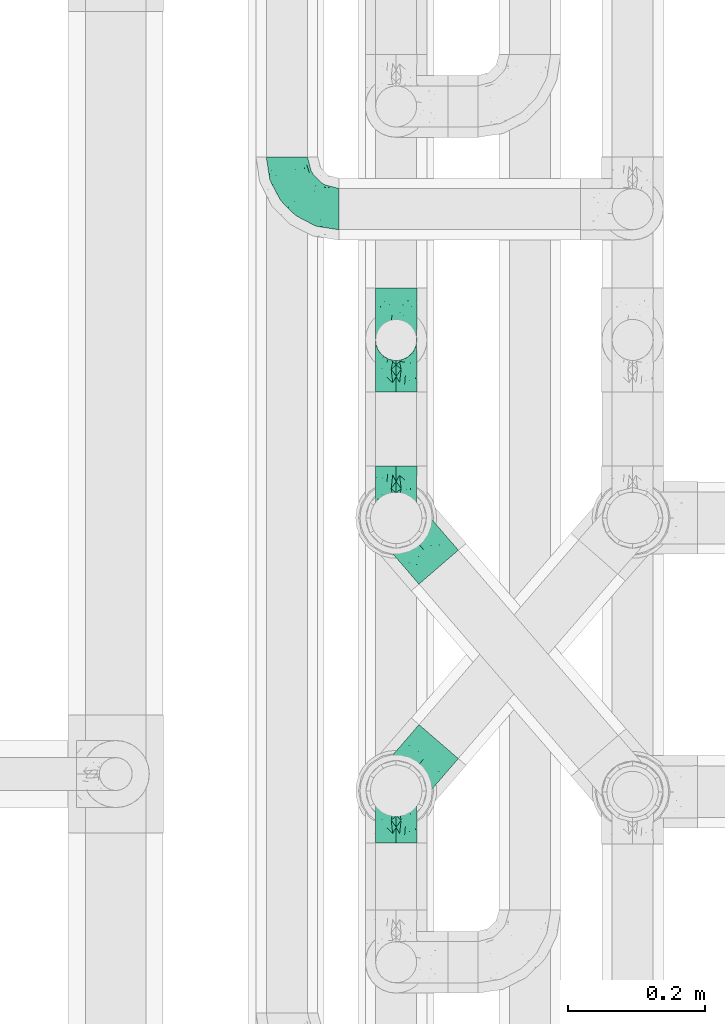
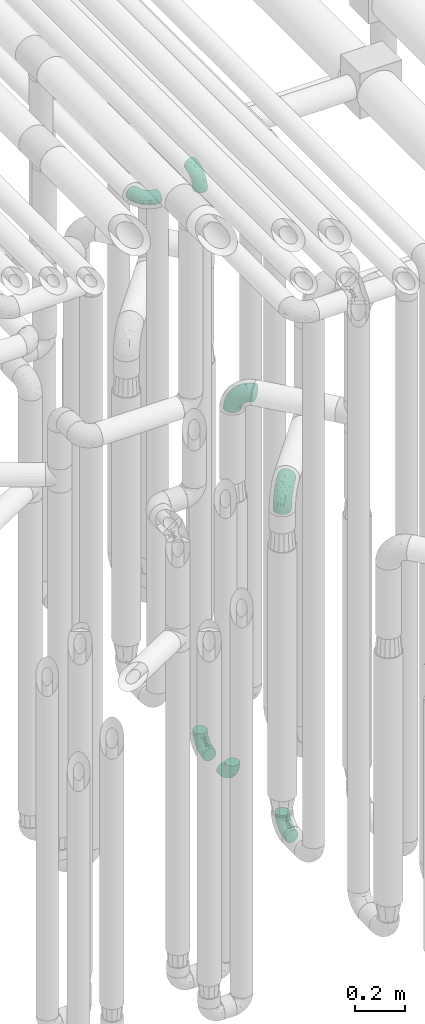
# One storey, part 615 of 827: 7 flow fittings.
"""IFC2X3 building model written with IfcOpenShell, lengths in millimetres."""

from ifc_helpers import new_model, entity, si_unit, converted_unit, derived_unit, direction, frame, origin, place, context, subcontext, project, spatial, faceted_brep, source, transform, mapped, material, type_object, type_shapes, element, save


model = new_model("IFC2X3")

# Units and contexts
model_context = context("Model", 3, precision=0.01, world=origin(), true_north=direction((6.12303176911189e-17, 1.0)))
body_context = subcontext(model_context, "Body", "Model", "MODEL_VIEW")
ifc_project = project(units=[si_unit("LENGTHUNIT", "METRE", prefix="MILLI"), si_unit("AREAUNIT", "SQUARE_METRE"), si_unit("VOLUMEUNIT", "CUBIC_METRE"), converted_unit("PLANEANGLEUNIT", "DEGREE", entity("IfcRatioMeasure", 0.0174532925199433), si_unit("PLANEANGLEUNIT", "RADIAN"), dimensions=[0, 0, 0, 0, 0, 0, 0]), si_unit("MASSUNIT", "GRAM", prefix="KILO"), derived_unit("MASSDENSITYUNIT", [(si_unit("MASSUNIT", "GRAM", prefix="KILO"), 1), (si_unit("LENGTHUNIT", "METRE"), -3)]), derived_unit("MOMENTOFINERTIAUNIT", [(si_unit("LENGTHUNIT", "METRE"), 4)]), si_unit("TIMEUNIT", "SECOND"), si_unit("FREQUENCYUNIT", "HERTZ"), si_unit("THERMODYNAMICTEMPERATUREUNIT", "DEGREE_CELSIUS"), derived_unit("THERMALTRANSMITTANCEUNIT", [(si_unit("MASSUNIT", "GRAM", prefix="KILO"), 1), (si_unit("THERMODYNAMICTEMPERATUREUNIT", "KELVIN"), -1), (si_unit("TIMEUNIT", "SECOND"), -3)]), derived_unit("VOLUMETRICFLOWRATEUNIT", [(si_unit("LENGTHUNIT", "METRE"), 3), (si_unit("TIMEUNIT", "SECOND"), -1)]), derived_unit("MASSFLOWRATEUNIT", [(si_unit("MASSUNIT", "GRAM", prefix="KILO"), 1), (si_unit("TIMEUNIT", "SECOND"), -1)]), derived_unit("ROTATIONALFREQUENCYUNIT", [(si_unit("TIMEUNIT", "SECOND"), -1)]), si_unit("ELECTRICCURRENTUNIT", "AMPERE"), si_unit("ELECTRICVOLTAGEUNIT", "VOLT"), si_unit("POWERUNIT", "WATT"), si_unit("FORCEUNIT", "NEWTON", prefix="KILO"), si_unit("ILLUMINANCEUNIT", "LUX"), si_unit("LUMINOUSFLUXUNIT", "LUMEN"), si_unit("LUMINOUSINTENSITYUNIT", "CANDELA"), derived_unit("USERDEFINED", [(si_unit("MASSUNIT", "GRAM", prefix="KILO"), -1), (si_unit("LENGTHUNIT", "METRE"), -2), (si_unit("TIMEUNIT", "SECOND"), 3), (si_unit("LUMINOUSFLUXUNIT", "LUMEN"), 1)]), derived_unit("LINEARVELOCITYUNIT", [(si_unit("LENGTHUNIT", "METRE"), 1), (si_unit("TIMEUNIT", "SECOND"), -1)]), si_unit("PRESSUREUNIT", "PASCAL"), derived_unit("USERDEFINED", [(si_unit("LENGTHUNIT", "METRE"), -2), (si_unit("MASSUNIT", "GRAM", prefix="KILO"), 1), (si_unit("TIMEUNIT", "SECOND"), -2)]), derived_unit("LINEARFORCEUNIT", [(si_unit("MASSUNIT", "GRAM", prefix="KILO"), 1), (si_unit("LENGTHUNIT", "METRE"), 1), (si_unit("TIMEUNIT", "SECOND"), -2), (si_unit("LENGTHUNIT", "METRE"), -1)]), derived_unit("PLANARFORCEUNIT", [(si_unit("MASSUNIT", "GRAM", prefix="KILO"), 1), (si_unit("LENGTHUNIT", "METRE"), 1), (si_unit("TIMEUNIT", "SECOND"), -2), (si_unit("LENGTHUNIT", "METRE"), -2)])], contexts=[model_context])

# Site, building, storey
site_placement = place(None, origin())
site = spatial("IfcSite", under=ifc_project, at=site_placement, CompositionType="ELEMENT")
building_placement = place(site_placement, origin())
building = spatial("IfcBuilding", under=site, at=building_placement, CompositionType="ELEMENT")
storey_placement = place(building_placement, frame((0.0, 0.0, 28200.0)))
storey = spatial("IfcBuildingStorey", under=building, at=storey_placement, Name="08", CompositionType="ELEMENT", Elevation=28200.0)

# Flow fittings
ifc_material = material()
pipe_fitting_type_1 = type_object("IfcPipeFittingType", Name="ADSK_1", PredefinedType="NOTDEFINED", material=ifc_material)
shared_shape_1 = source(origin(), body_context, "Body", "Brep", [
    faceted_brep([(-76.0, 15.07, -26.11), (-76.0, 7.8, -29.12), (-76.0, 0.0, -30.15), (-76.0, -7.8, -29.12), (-76.0, -15.08, -26.11), (-76.0, -21.32, -21.32), (-76.0, -26.11, -15.08), (-76.0, -29.12, -7.8), (-76.0, -30.15, 0.0), (-76.0, -29.12, 7.8), (-76.0, -26.11, 15.07), (-76.0, -21.32, 21.32), (-76.0, -15.08, 26.11), (-76.0, -7.8, 29.12), (-76.0, 0.0, 30.15), (-76.0, 7.8, 29.12), (-76.0, 15.07, 26.11), (-76.0, 21.32, 21.32), (-76.0, 26.11, 15.07), (-76.0, 29.12, 7.8), (-76.0, 30.15, 0.0), (-76.0, 29.12, -7.8), (-76.0, 26.11, -15.08), (-76.0, 21.32, -21.32), (0.0, 76.0, -30.15), (-7.8, 76.0, -29.12), (-15.07, 76.0, -26.11), (-21.32, 76.0, -21.32), (-26.11, 76.0, -15.08), (-29.12, 76.0, -7.8), (-30.15, 76.0, 0.0), (-29.12, 76.0, 7.8), (-26.11, 76.0, 15.07), (-21.32, 76.0, 21.32), (-15.07, 76.0, 26.11), (-7.8, 76.0, 29.12), (0.0, 76.0, 30.15), (7.8, 76.0, 29.12), (15.08, 76.0, 26.11), (21.32, 76.0, 21.32), (26.11, 76.0, 15.07), (29.12, 76.0, 7.8), (30.15, 76.0, 0.0), (29.12, 76.0, -7.8), (26.11, 76.0, -15.08), (21.32, 76.0, -21.32), (15.08, 76.0, -26.11), (7.8, 76.0, -29.12), (10.79, 31.43, 21.07), (4.32, 31.7, 25.72), (1.65, 15.19, 19.92), (-61.17, -27.8, 0.0), (-51.1, -25.49, 9.84), (-56.14, -10.61, 27.27), (-31.7, -4.32, 25.72), (-39.75, 1.72, 29.41), (-43.2, -24.95, 0.0), (-1.86, 1.86, 0.0), (4.49, 7.65, 5.78), (-7.82, -4.61, 5.83), (-56.21, -22.79, 17.21), (-58.98, -3.38, 29.7), (-53.96, 5.6, 30.07), (-10.86, 10.86, 25.48), (-17.2, -2.6, 20.44), (-49.15, -16.01, 22.7), (-22.18, -14.24, 7.99), (-28.4, -17.42, 0.0), (-13.61, -9.88, 0.0), (-39.0, 23.48, 27.76), (-58.76, 12.54, 28.36), (-41.61, 15.41, 29.48), (16.01, 49.15, 22.7), (-58.55, 25.93, 19.53), (-51.53, 33.5, 13.51), (-64.92, 28.76, 12.4), (-7.48, 23.14, 28.25), (-1.72, 39.75, 29.41), (-12.04, 27.88, 29.88), (-63.91, 18.81, 24.52), (-11.63, 65.16, 28.18), (-4.97, 57.02, 30.05), (9.88, 13.61, 0.0), (-62.5, 31.74, 5.02), (-45.17, 30.98, 21.2), (-21.78, 9.76, 28.58), (10.61, 56.14, 27.27), (-32.09, 54.42, 13.26), (22.79, 56.21, 17.21), (15.38, 31.17, 15.63), (25.49, 51.1, 9.84), (21.84, 36.35, 5.92), (24.95, 43.2, 0.0), (3.38, 58.98, 29.7), (-31.17, -15.38, 15.63), (-39.39, 41.78, 15.45), (-34.56, 41.13, 20.79), (-39.81, -23.25, 5.49), (27.8, 61.17, 0.0), (-31.74, 62.5, 5.02), (-53.07, 36.29, 0.0), (-42.95, 42.95, 7.29), (-36.29, 53.07, 0.0), (-19.83, 58.51, 24.79), (-25.48, 60.2, 19.41), (-14.53, 50.96, 28.57), (-13.31, 37.09, 30.07), (-26.16, 40.06, 26.4), (-32.43, -10.35, 21.9), (17.42, 28.4, 0.0), (14.24, 22.18, 7.99), (-38.67, 9.72, 30.15), (-24.66, 17.36, 30.09), (-37.08, 31.49, 24.99), (-49.27, 22.83, 25.24), (-20.8, 38.81, 28.63), (-27.58, 27.58, 29.2), (-36.07, -20.23, 10.71), (-15.19, -6.16, 14.9), (6.6, 15.4, 14.49), (-2.51, 2.51, 11.35), (-65.16, 11.63, -28.18), (-49.15, -16.01, -22.7), (-57.02, 4.97, -30.05), (-25.93, 58.55, -19.53), (-33.5, 51.53, -13.51), (-28.76, 64.92, -12.4), (-60.2, 25.48, -19.41), (-58.51, 19.83, -24.79), (4.61, 7.82, -5.83), (-7.65, -4.49, -5.78), (-2.51, 2.51, -11.35), (-62.5, 31.74, -5.02), (-50.96, 14.53, -28.57), (-37.09, 13.31, -30.07), (-42.95, 42.95, -7.29), (25.49, 51.1, -9.84), (22.79, 56.21, -17.21), (-40.06, 26.16, -26.4), (3.38, 58.98, -29.7), (-5.6, 53.96, -30.07), (-27.88, 12.04, -29.88), (-9.76, 21.78, -28.58), (-23.14, 7.48, -28.25), (-51.1, -25.49, -9.84), (15.38, 31.17, -15.63), (16.01, 49.15, -22.7), (-23.48, 39.0, -27.76), (-12.54, 58.76, -28.36), (-15.41, 41.61, -29.48), (-56.21, -22.79, -17.21), (-9.72, 38.67, -30.15), (-17.36, 24.66, -30.09), (-22.18, -14.24, -7.99), (-41.13, 34.56, -20.79), (-31.74, 62.5, -5.02), (-58.98, -3.38, -29.7), (-31.17, -15.38, -15.63), (-56.14, -10.61, -27.27), (14.24, 22.18, -7.99), (23.25, 39.81, -5.49), (-31.49, 37.08, -24.99), (-15.19, -6.16, -14.9), (1.65, 15.19, -19.92), (-18.81, 63.91, -24.52), (-32.59, -11.62, -20.84), (-31.7, -4.32, -25.72), (-17.2, -2.6, -20.44), (-39.75, 1.72, -29.41), (-54.42, 32.09, -13.26), (-30.98, 45.17, -21.2), (10.61, 56.14, -27.27), (10.23, 31.31, -21.52), (4.32, 31.7, -25.72), (-41.78, 39.39, -15.45), (-1.72, 39.75, -29.41), (-36.35, -21.84, -5.92), (-22.83, 49.27, -25.24), (-38.81, 20.8, -28.63), (-27.58, 27.58, -29.2), (-10.86, 10.86, -25.48), (20.23, 36.07, -10.71), (6.6, 15.4, -14.49)], [[[0, 1, 2, 3, 4, 5, 6, 7, 8, 9, 10, 11, 12, 13, 14, 15, 16, 17, 18, 19, 20, 21, 22, 23]], [[24, 25, 26, 27, 28, 29, 30, 31, 32, 33, 34, 35, 36, 37, 38, 39, 40, 41, 42, 43, 44, 45, 46, 47]], [[48, 49, 50]], [[51, 52, 9]], [[53, 54, 55]], [[9, 52, 10]], [[56, 52, 51]], [[57, 58, 59]], [[11, 10, 60]], [[14, 61, 62]], [[63, 54, 64]], [[65, 12, 11]], [[65, 53, 12]], [[66, 67, 68]], [[69, 70, 71]], [[72, 39, 38]], [[73, 74, 75]], [[15, 70, 16]], [[76, 77, 78]], [[16, 79, 17]], [[13, 61, 14]], [[35, 80, 81]], [[14, 62, 15]], [[17, 73, 18]], [[57, 82, 58]], [[20, 19, 83]], [[75, 19, 18]], [[70, 15, 62]], [[73, 84, 74]], [[78, 85, 76]], [[38, 86, 72]], [[32, 31, 87]], [[88, 89, 90]], [[91, 92, 90]], [[72, 86, 49]], [[36, 93, 37]], [[75, 83, 19]], [[36, 35, 81]], [[60, 94, 65]], [[40, 90, 41]], [[95, 96, 87]], [[88, 90, 40]], [[66, 97, 67]], [[90, 98, 41]], [[40, 39, 88]], [[99, 31, 30]], [[20, 83, 100]], [[101, 102, 100]], [[52, 60, 10]], [[102, 99, 30]], [[96, 103, 104]], [[83, 101, 100]], [[12, 53, 13]], [[104, 103, 33]], [[105, 106, 81]], [[107, 105, 103]], [[64, 54, 108]], [[80, 103, 105]], [[80, 35, 34]], [[34, 33, 103]], [[86, 38, 37]], [[109, 110, 82]], [[71, 111, 112]], [[69, 107, 113]], [[79, 73, 17]], [[114, 113, 84]], [[33, 32, 104]], [[115, 107, 116]], [[105, 115, 106]], [[93, 81, 77]], [[54, 53, 65]], [[61, 53, 55]], [[108, 94, 64]], [[54, 63, 85]], [[93, 86, 37]], [[77, 76, 49]], [[77, 49, 86]], [[49, 63, 50]], [[60, 52, 117]], [[65, 11, 60]], [[39, 72, 88]], [[89, 88, 72]], [[71, 70, 62]], [[79, 70, 114]], [[103, 96, 107]], [[69, 113, 114]], [[112, 106, 116]], [[77, 81, 106]], [[112, 116, 71]], [[112, 55, 85]], [[64, 50, 63]], [[57, 59, 68]], [[32, 87, 104]], [[96, 104, 87]], [[94, 118, 64]], [[50, 119, 89]], [[50, 64, 118]], [[50, 89, 48]], [[81, 93, 36]], [[86, 93, 77]], [[53, 61, 13]], [[62, 61, 55]], [[71, 62, 111]], [[69, 71, 116]], [[95, 101, 74]], [[99, 101, 87]], [[118, 66, 59]], [[117, 97, 66]], [[117, 66, 94]], [[91, 89, 110]], [[91, 110, 109]], [[110, 89, 119]], [[9, 8, 51]], [[98, 90, 92]], [[98, 42, 41]], [[101, 83, 74]], [[101, 99, 102]], [[87, 31, 99]], [[62, 55, 111]], [[55, 112, 111]], [[107, 69, 116]], [[70, 69, 114]], [[107, 96, 113]], [[84, 113, 96]], [[84, 96, 95]], [[114, 84, 73]], [[70, 79, 16]], [[73, 79, 114]], [[54, 85, 55]], [[76, 85, 63]], [[49, 76, 63]], [[77, 106, 78]], [[106, 112, 78]], [[85, 78, 112]], [[73, 75, 18]], [[83, 75, 74]], [[103, 80, 34]], [[81, 80, 105]], [[101, 95, 87]], [[84, 95, 74]], [[106, 115, 116]], [[105, 107, 115]], [[120, 59, 58]], [[82, 110, 58]], [[119, 58, 110]], [[118, 59, 120]], [[66, 68, 59]], [[54, 65, 108]], [[94, 108, 65]], [[66, 118, 94]], [[50, 118, 120]], [[50, 120, 119]], [[119, 120, 58]], [[89, 72, 48]], [[49, 48, 72]], [[60, 117, 94]], [[117, 52, 97]], [[52, 56, 97]], [[67, 97, 56]], [[92, 91, 109]], [[89, 91, 90]], [[121, 1, 0]], [[122, 5, 4]], [[2, 1, 123]], [[124, 125, 126]], [[127, 128, 23]], [[129, 130, 131]], [[100, 132, 20]], [[133, 134, 123]], [[135, 100, 102]], [[136, 137, 44]], [[133, 128, 138]], [[24, 139, 140]], [[141, 142, 143]], [[121, 128, 133]], [[6, 144, 7]], [[137, 145, 146]], [[144, 51, 7]], [[147, 148, 149]], [[144, 6, 150]], [[149, 151, 152]], [[153, 68, 67]], [[154, 128, 127]], [[30, 155, 102]], [[43, 42, 98]], [[156, 3, 2]], [[157, 144, 150]], [[158, 4, 3]], [[24, 140, 25]], [[155, 135, 102]], [[159, 160, 109]], [[30, 29, 155]], [[147, 138, 161]], [[27, 124, 28]], [[57, 129, 82]], [[162, 163, 131]], [[27, 26, 164]], [[148, 26, 25]], [[165, 166, 167]], [[24, 47, 139]], [[143, 168, 141]], [[22, 21, 169]], [[125, 124, 170]], [[148, 25, 140]], [[46, 146, 171]], [[158, 122, 4]], [[0, 23, 128]], [[1, 121, 123]], [[109, 82, 159]], [[45, 44, 137]], [[146, 46, 45]], [[136, 43, 98]], [[132, 21, 20]], [[136, 98, 92]], [[172, 173, 146]], [[46, 171, 47]], [[43, 136, 44]], [[174, 154, 169]], [[171, 173, 175]], [[6, 5, 150]], [[126, 29, 28]], [[176, 56, 144]], [[122, 158, 166]], [[164, 124, 27]], [[177, 161, 170]], [[23, 22, 127]], [[178, 138, 179]], [[133, 178, 134]], [[156, 123, 168]], [[156, 158, 3]], [[168, 143, 166]], [[168, 166, 158]], [[166, 180, 167]], [[173, 171, 146]], [[139, 171, 175]], [[172, 145, 163]], [[173, 180, 142]], [[5, 122, 150]], [[157, 150, 122]], [[137, 136, 181]], [[146, 45, 137]], [[149, 148, 140]], [[164, 148, 177]], [[128, 154, 138]], [[147, 161, 177]], [[152, 134, 179]], [[168, 123, 134]], [[152, 179, 149]], [[152, 175, 142]], [[57, 130, 129]], [[157, 165, 167]], [[22, 169, 127]], [[154, 127, 169]], [[163, 167, 180]], [[162, 157, 167]], [[173, 163, 180]], [[182, 163, 145]], [[123, 156, 2]], [[158, 156, 168]], [[171, 139, 47]], [[140, 139, 175]], [[149, 140, 151]], [[147, 149, 179]], [[174, 135, 125]], [[132, 135, 169]], [[176, 157, 153]], [[176, 153, 67]], [[153, 157, 162]], [[182, 159, 129]], [[181, 160, 159]], [[181, 159, 145]], [[51, 144, 56]], [[51, 8, 7]], [[135, 132, 100]], [[169, 21, 132]], [[126, 155, 29]], [[135, 155, 125]], [[140, 175, 151]], [[175, 152, 151]], [[138, 147, 179]], [[148, 147, 177]], [[138, 154, 161]], [[170, 161, 154]], [[170, 154, 174]], [[177, 170, 124]], [[148, 164, 26]], [[124, 164, 177]], [[173, 142, 175]], [[143, 142, 180]], [[166, 143, 180]], [[168, 134, 141]], [[134, 152, 141]], [[142, 141, 152]], [[124, 126, 28]], [[155, 126, 125]], [[128, 121, 0]], [[123, 121, 133]], [[135, 174, 169]], [[170, 174, 125]], [[134, 178, 179]], [[133, 138, 178]], [[130, 153, 162]], [[68, 153, 130]], [[57, 68, 130]], [[182, 129, 131]], [[159, 82, 129]], [[157, 122, 165]], [[166, 165, 122]], [[163, 162, 167]], [[162, 131, 130]], [[145, 172, 146]], [[163, 173, 172]], [[159, 182, 145]], [[131, 163, 182]], [[56, 176, 67]], [[157, 176, 144]], [[137, 181, 145]], [[181, 136, 160]], [[136, 92, 160]], [[109, 160, 92]]]),
])
type_shapes(pipe_fitting_type_1, [shared_shape_1])
for number, where, z_axis, x_axis, name in (
    (1, (36470.03, 12181.17, 3000.0), (0.0, 0.0, 1.0), (0.0, -1.0, 0.0), "ADSK_1"),
    (2, (36629.64, 11730.2, 400.0), (-1.0, 0.0, 0.0), (0.0, -1.0, 0.0), "ADSK_1"),
    (3, (36629.64, 11331.59, 400.0), (1.0, 0.0, 0.0), (0.0, 1.0, 0.0), "ADSK_1"),
    (4, (36629.64, 11990.2, 3200.0), (1.0, 0.0, 0.0), (0.0, -1.0, 0.0), "ADSK_1"),
    (5, (36629.64, 11990.2, 400.0), (1.0, 0.0, 0.0), (0.0, 1.0, 0.0), "ADSK_1"),
):
    element("IfcFlowFitting", number, at=place(storey_placement, frame(where, z_axis=z_axis, x_axis=x_axis)), inside=storey, type_object=pipe_fitting_type_1, material=ifc_material, Name=name, ObjectType="ADSK_1", context=body_context, shape_type="MappedRepresentation", body=[
        mapped(shared_shape_1, transform((0.0, 0.0, 0.0), scale=1.0)),
    ])
pipe_fitting_type_2 = type_object("IfcPipeFittingType", Name="ADSK_1", PredefinedType="NOTDEFINED", material=ifc_material)
shared_shape_2 = source(origin(), body_context, "Body", "Brep", [
    faceted_brep([(-95.0, 19.02, -32.95), (-95.0, 9.85, -36.75), (-95.0, 0.0, -38.05), (-95.0, -9.85, -36.75), (-95.0, -19.03, -32.95), (-95.0, -26.91, -26.91), (-95.0, -32.95, -19.03), (-95.0, -36.75, -9.85), (-95.0, -38.05, 0.0), (-95.0, -36.75, 9.85), (-95.0, -32.95, 19.02), (-95.0, -26.91, 26.91), (-95.0, -19.03, 32.95), (-95.0, -9.85, 36.75), (-95.0, 0.0, 38.05), (-95.0, 9.85, 36.75), (-95.0, 19.02, 32.95), (-95.0, 26.91, 26.91), (-95.0, 32.95, 19.02), (-95.0, 36.75, 9.85), (-95.0, 38.05, 0.0), (-95.0, 36.75, -9.85), (-95.0, 32.95, -19.03), (-95.0, 26.91, -26.91), (0.0, 95.0, -38.05), (-9.85, 95.0, -36.75), (-19.02, 95.0, -32.95), (-26.91, 95.0, -26.91), (-32.95, 95.0, -19.03), (-36.75, 95.0, -9.85), (-38.05, 95.0, 0.0), (-36.75, 95.0, 9.85), (-32.95, 95.0, 19.02), (-26.91, 95.0, 26.91), (-19.02, 95.0, 32.95), (-9.85, 95.0, 36.75), (0.0, 95.0, 38.05), (9.85, 95.0, 36.75), (19.03, 95.0, 32.95), (26.91, 95.0, 26.91), (32.95, 95.0, 19.02), (36.75, 95.0, 9.85), (38.05, 95.0, 0.0), (36.75, 95.0, -9.85), (32.95, 95.0, -19.03), (26.91, 95.0, -26.91), (19.03, 95.0, -32.95), (9.85, 95.0, -36.75), (-7.99, -4.96, 6.3), (-0.92, 0.92, 0.0), (4.62, 8.1, 8.01), (-76.19, -35.57, 0.0), (-64.32, -32.32, 12.43), (20.51, 62.45, 28.68), (-60.56, -33.52, 0.0), (-70.4, -13.47, 34.42), (-39.61, -5.88, 32.32), (-49.6, 2.07, 37.1), (-70.34, -28.81, 21.71), (14.64, 40.81, 26.5), (5.88, 39.61, 32.32), (3.59, 20.77, 25.31), (-40.45, 68.06, 16.75), (-62.45, -20.51, 28.68), (-44.52, -26.87, 0.0), (-28.47, -20.22, 0.0), (-26.43, -17.83, 8.75), (-76.1, 39.63, 10.76), (-72.74, 37.58, 18.19), (-60.35, 46.18, 14.61), (-13.4, 13.4, 32.12), (-20.77, -3.59, 25.31), (-14.66, 81.47, 35.56), (-6.22, 71.26, 37.92), (-57.5, 42.48, 22.79), (-15.0, 34.74, 37.7), (-27.1, 12.08, 36.05), (-9.2, 28.81, 35.63), (-79.98, 23.7, 30.95), (-73.68, -4.3, 37.48), (-30.74, 21.67, 37.97), (-62.36, 47.59, 6.79), (-72.71, 32.83, 24.69), (-67.42, 7.02, 37.95), (-32.13, 75.27, 24.51), (-43.46, 51.47, 26.26), (-24.98, 73.15, 31.29), (20.59, 41.28, 19.85), (7.79, 16.09, 15.86), (-73.21, 42.39, 0.0), (-54.73, 54.73, 0.0), (-73.44, 15.79, 35.79), (-5.94, 4.32, 20.43), (28.81, 70.34, 21.71), (32.32, 64.32, 12.43), (-53.59, 26.2, 35.09), (-52.02, 19.31, 37.21), (21.38, 33.53, 10.34), (26.87, 44.52, 0.0), (-48.28, 12.14, 38.05), (4.3, 73.68, 37.48), (-44.08, -25.52, 12.79), (-41.28, -20.59, 19.85), (35.57, 76.19, 0.0), (-47.26, 54.3, 20.18), (-47.4, 61.99, 8.58), (-42.39, 73.21, 0.0), (-39.67, 78.86, 7.21), (-45.69, 36.84, 33.11), (-32.83, 50.13, 33.35), (13.47, 70.4, 34.42), (-18.25, 63.73, 36.07), (-40.63, -13.75, 27.22), (-16.63, 46.37, 37.95), (-53.47, 38.79, 28.59), (-26.07, 48.54, 36.15), (-34.51, 34.51, 36.86), (-2.07, 49.6, 37.1), (-22.79, -10.49, 19.23), (-61.73, 28.67, 31.87), (9.65, 14.7, 0.0), (20.22, 28.47, 0.0), (33.52, 60.56, 0.0), (-11.42, -5.44, 13.25), (-14.7, -9.65, 0.0), (-81.47, 14.66, -35.56), (-62.45, -20.51, -28.68), (-71.26, 6.22, -37.92), (-75.27, 32.13, -24.51), (-73.15, 24.98, -31.29), (13.47, 70.4, -34.42), (5.88, 39.61, -32.32), (-2.07, 49.6, -37.1), (-78.86, 39.67, -7.21), (-70.4, -13.47, -34.42), (-39.61, -5.88, -32.32), (-61.99, 47.4, -8.58), (32.32, 64.32, -12.43), (28.81, 70.34, -21.71), (-63.73, 18.25, -36.07), (-50.13, 32.83, -33.35), (4.3, 73.68, -37.48), (-7.02, 67.42, -37.95), (-39.63, 76.1, -10.76), (-46.18, 60.35, -14.61), (-47.59, 62.36, -6.79), (-64.32, -32.32, -12.43), (-26.2, 53.59, -35.09), (-15.79, 73.44, -35.79), (-19.31, 52.02, -37.21), (-37.58, 72.74, -18.19), (-70.34, -28.81, -21.71), (-42.48, 57.5, -22.79), (-38.79, 53.47, -28.59), (-51.47, 43.46, -26.26), (-32.83, 72.71, -24.69), (-46.37, 16.63, -37.95), (-73.68, -4.3, -37.48), (-41.28, -20.59, -19.85), (-44.08, -25.52, -12.79), (13.75, 40.63, -27.22), (20.51, 62.45, -28.68), (-68.06, 40.45, -16.75), (-54.3, 47.26, -20.18), (-12.14, 48.28, -38.05), (-21.67, 30.74, -37.97), (-36.84, 45.69, -33.11), (-11.42, -5.44, -13.25), (7.79, 16.09, -15.86), (4.62, 8.1, -8.01), (-23.7, 79.98, -30.95), (-26.43, -17.83, -8.75), (-7.99, -4.96, -6.3), (-40.81, -14.64, -26.5), (-20.77, -3.59, -25.31), (-34.74, 15.0, -37.7), (-12.08, 27.1, -36.05), (-28.81, 9.2, -35.63), (-22.79, -10.49, -19.23), (21.38, 33.53, -10.34), (20.59, 41.28, -19.85), (-48.54, 26.07, -36.15), (-49.6, 2.07, -37.1), (-13.4, 13.4, -32.12), (3.59, 20.77, -25.31), (-28.67, 61.73, -31.87), (-34.51, 34.51, -36.86), (-5.94, 4.32, -20.43)], [[[0, 1, 2, 3, 4, 5, 6, 7, 8, 9, 10, 11, 12, 13, 14, 15, 16, 17, 18, 19, 20, 21, 22, 23]], [[24, 25, 26, 27, 28, 29, 30, 31, 32, 33, 34, 35, 36, 37, 38, 39, 40, 41, 42, 43, 44, 45, 46, 47]], [[48, 49, 50]], [[51, 52, 9]], [[53, 39, 38]], [[9, 52, 10]], [[54, 52, 51]], [[55, 56, 57]], [[11, 10, 58]], [[59, 60, 61]], [[32, 31, 62]], [[63, 12, 11]], [[63, 55, 12]], [[64, 65, 66]], [[67, 68, 69]], [[70, 56, 71]], [[35, 72, 73]], [[69, 68, 74]], [[75, 76, 77]], [[16, 78, 17]], [[13, 79, 14]], [[76, 75, 80]], [[67, 69, 81]], [[18, 17, 82]], [[14, 79, 83]], [[20, 19, 67]], [[84, 85, 86]], [[87, 61, 88]], [[89, 81, 90]], [[18, 82, 68]], [[15, 91, 16]], [[14, 83, 15]], [[71, 92, 61]], [[17, 78, 82]], [[93, 87, 94]], [[95, 91, 96]], [[97, 98, 94]], [[86, 72, 34]], [[96, 99, 80]], [[37, 36, 100]], [[40, 39, 93]], [[40, 94, 41]], [[64, 66, 101]], [[93, 94, 40]], [[58, 102, 63]], [[94, 103, 41]], [[94, 87, 97]], [[104, 69, 74]], [[34, 33, 86]], [[105, 69, 104]], [[52, 58, 10]], [[106, 107, 30]], [[108, 109, 85]], [[105, 106, 90]], [[53, 110, 60]], [[86, 111, 72]], [[86, 109, 111]], [[33, 84, 86]], [[12, 55, 13]], [[112, 56, 63]], [[110, 38, 37]], [[34, 72, 35]], [[36, 35, 73]], [[111, 113, 73]], [[105, 107, 106]], [[110, 53, 38]], [[74, 114, 85]], [[91, 15, 83]], [[105, 90, 81]], [[107, 62, 31]], [[33, 32, 84]], [[115, 109, 116]], [[111, 115, 113]], [[100, 73, 117]], [[56, 55, 63]], [[79, 55, 57]], [[102, 118, 112]], [[56, 70, 76]], [[100, 110, 37]], [[117, 77, 60]], [[117, 60, 110]], [[60, 70, 61]], [[58, 52, 101]], [[63, 11, 58]], [[39, 53, 93]], [[87, 93, 53]], [[96, 91, 83]], [[78, 91, 119]], [[32, 62, 84]], [[84, 62, 104]], [[86, 85, 109]], [[85, 114, 108]], [[80, 113, 116]], [[117, 73, 113]], [[80, 116, 96]], [[80, 57, 76]], [[71, 112, 118]], [[61, 87, 59]], [[62, 107, 105]], [[97, 120, 121]], [[70, 71, 61]], [[71, 118, 92]], [[73, 100, 36]], [[110, 100, 117]], [[55, 79, 13]], [[83, 79, 57]], [[96, 83, 99]], [[116, 108, 95]], [[50, 97, 88]], [[97, 87, 88]], [[50, 49, 120]], [[122, 94, 98]], [[89, 20, 67]], [[105, 81, 69]], [[89, 67, 81]], [[68, 19, 18]], [[68, 67, 19]], [[74, 68, 82]], [[114, 82, 119]], [[74, 85, 104]], [[82, 114, 74]], [[114, 119, 108]], [[95, 108, 119]], [[116, 109, 108]], [[123, 48, 50]], [[97, 50, 120]], [[123, 50, 88]], [[91, 95, 119]], [[116, 95, 96]], [[84, 104, 85]], [[104, 62, 105]], [[83, 57, 99]], [[57, 80, 99]], [[66, 48, 123]], [[66, 124, 48]], [[118, 66, 123]], [[124, 66, 65]], [[66, 118, 101]], [[54, 64, 52]], [[124, 49, 48]], [[30, 107, 31]], [[91, 78, 16]], [[82, 78, 119]], [[56, 76, 57]], [[77, 76, 70]], [[60, 77, 70]], [[77, 117, 75]], [[117, 113, 75]], [[113, 80, 75]], [[9, 8, 51]], [[103, 94, 122]], [[103, 42, 41]], [[73, 72, 111]], [[113, 115, 116]], [[111, 109, 115]], [[102, 112, 63]], [[71, 56, 112]], [[118, 102, 101]], [[92, 123, 88]], [[123, 92, 118]], [[61, 92, 88]], [[87, 53, 59]], [[60, 59, 53]], [[97, 121, 98]], [[58, 101, 102]], [[64, 101, 52]], [[125, 1, 0]], [[126, 5, 4]], [[2, 1, 127]], [[1, 125, 127]], [[128, 129, 23]], [[130, 131, 132]], [[89, 133, 20]], [[126, 134, 135]], [[136, 89, 90]], [[137, 138, 44]], [[139, 129, 140]], [[24, 141, 142]], [[143, 144, 145]], [[125, 129, 139]], [[6, 146, 7]], [[147, 148, 149]], [[146, 51, 7]], [[143, 150, 144]], [[146, 6, 151]], [[152, 153, 154]], [[126, 4, 134]], [[0, 23, 129]], [[28, 155, 150]], [[43, 42, 103]], [[54, 146, 64]], [[139, 156, 127]], [[157, 3, 2]], [[151, 158, 159]], [[160, 131, 161]], [[22, 21, 162]], [[136, 144, 163]], [[149, 164, 165]], [[24, 142, 25]], [[166, 140, 154]], [[154, 129, 128]], [[143, 30, 29]], [[167, 168, 169]], [[155, 28, 27]], [[26, 170, 27]], [[171, 167, 172]], [[26, 25, 148]], [[27, 170, 155]], [[173, 135, 174]], [[144, 150, 152]], [[175, 176, 177]], [[24, 47, 141]], [[45, 161, 46]], [[148, 25, 142]], [[176, 175, 165]], [[64, 159, 171]], [[138, 45, 44]], [[130, 46, 161]], [[137, 44, 43]], [[178, 159, 158]], [[137, 103, 122]], [[163, 144, 152]], [[136, 133, 89]], [[103, 137, 43]], [[6, 5, 151]], [[178, 158, 173]], [[134, 4, 3]], [[178, 173, 174]], [[137, 98, 179]], [[145, 90, 106]], [[138, 180, 161]], [[46, 130, 47]], [[136, 90, 145]], [[133, 162, 21]], [[23, 22, 128]], [[139, 140, 181]], [[139, 181, 156]], [[157, 127, 182]], [[157, 134, 3]], [[182, 177, 135]], [[182, 135, 134]], [[135, 183, 174]], [[131, 130, 161]], [[141, 130, 132]], [[160, 180, 184]], [[131, 183, 176]], [[5, 126, 151]], [[158, 151, 126]], [[180, 138, 137]], [[161, 45, 138]], [[149, 148, 142]], [[170, 148, 185]], [[22, 162, 128]], [[128, 162, 163]], [[129, 154, 140]], [[154, 153, 166]], [[165, 156, 186]], [[182, 127, 156]], [[165, 186, 149]], [[165, 132, 176]], [[131, 184, 183]], [[187, 167, 178]], [[184, 168, 187]], [[167, 169, 172]], [[184, 180, 168]], [[174, 183, 184]], [[127, 157, 2]], [[134, 157, 182]], [[130, 141, 47]], [[142, 141, 132]], [[149, 142, 164]], [[186, 166, 147]], [[180, 179, 168]], [[169, 179, 120]], [[137, 179, 180]], [[179, 121, 120]], [[106, 30, 143]], [[136, 145, 144]], [[106, 143, 145]], [[150, 29, 28]], [[150, 143, 29]], [[152, 150, 155]], [[153, 155, 185]], [[152, 154, 163]], [[155, 153, 152]], [[153, 185, 166]], [[147, 166, 185]], [[186, 140, 166]], [[169, 120, 49]], [[169, 49, 172]], [[179, 169, 168]], [[148, 147, 185]], [[186, 147, 149]], [[128, 163, 154]], [[163, 162, 136]], [[142, 132, 164]], [[132, 165, 164]], [[171, 124, 65]], [[124, 171, 172]], [[64, 146, 159]], [[171, 159, 178]], [[171, 65, 64]], [[172, 49, 124]], [[162, 133, 136]], [[20, 133, 21]], [[148, 170, 26]], [[155, 170, 185]], [[131, 176, 132]], [[177, 176, 183]], [[135, 177, 183]], [[177, 182, 175]], [[182, 156, 175]], [[156, 165, 175]], [[51, 146, 54]], [[51, 8, 7]], [[129, 125, 0]], [[127, 125, 139]], [[140, 186, 181]], [[156, 181, 186]], [[158, 126, 173]], [[135, 173, 126]], [[187, 178, 174]], [[171, 178, 167]], [[184, 187, 174]], [[167, 187, 168]], [[180, 160, 161]], [[184, 131, 160]], [[98, 137, 122]], [[98, 121, 179]], [[151, 159, 146]]]),
])
type_shapes(pipe_fitting_type_2, [shared_shape_2])
for number, where, z_axis, x_axis, name in (
    (6, (36629.64, 11730.2, 2305.0), (0.756847522306242, 0.65359148401651, 0.0), (0.0, 0.0, 1.0), "ADSK_1"),
    (7, (36629.64, 11331.59, 2050.0), (-0.756825266247892, 0.653617255256322, 0.0), (0.0, 0.0, 1.0), "ADSK_1"),
):
    element("IfcFlowFitting", number, at=place(storey_placement, frame(where, z_axis=z_axis, x_axis=x_axis)), inside=storey, type_object=pipe_fitting_type_2, material=ifc_material, Name=name, ObjectType="ADSK_1", context=body_context, shape_type="MappedRepresentation", body=[
        mapped(shared_shape_2, transform((0.0, 0.0, 0.0), scale=1.0)),
    ])

save(model, "model.ifc")
